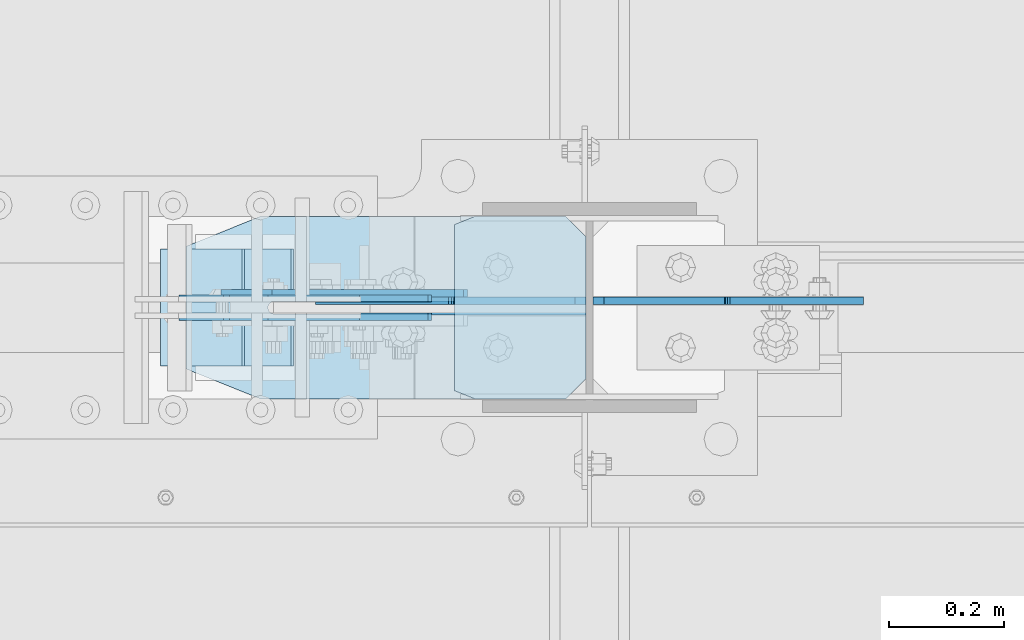
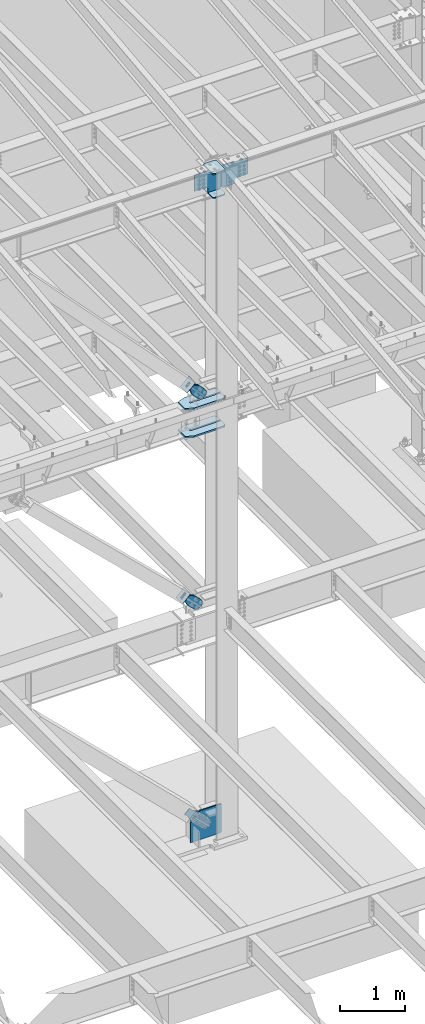
# One storey, part 1041 of 1179: 14 plates, 8 elements without a shape of their own.
"""IFC2X3 building model written with IfcOpenShell, lengths in millimetres."""

from ifc_helpers import new_model, si_unit, frame, origin_with_axes, place, context, subcontext, project, spatial, faceted_brep, material, type_object, element, aggregate, save


model = new_model("IFC2X3")

# Units and contexts
model_context = context("Model", 3, precision=1e-05, world=origin_with_axes())
body_context = subcontext(model_context, "Body", "Model", "MODEL_VIEW")
ifc_project = project(units=[si_unit("LENGTHUNIT", "METRE", prefix="MILLI"), si_unit("AREAUNIT", "SQUARE_METRE"), si_unit("VOLUMEUNIT", "CUBIC_METRE"), si_unit("MASSUNIT", "GRAM", prefix="KILO"), si_unit("TIMEUNIT", "SECOND"), si_unit("PLANEANGLEUNIT", "RADIAN"), si_unit("SOLIDANGLEUNIT", "STERADIAN"), si_unit("THERMODYNAMICTEMPERATUREUNIT", "DEGREE_CELSIUS"), si_unit("LUMINOUSINTENSITYUNIT", "LUMEN")], contexts=[model_context])

# Site, building, storey
site_placement = place(None, origin_with_axes())
site = spatial("IfcSite", under=ifc_project, at=site_placement, CompositionType="ELEMENT")
building_placement = place(site_placement, origin_with_axes())
building = spatial("IfcBuilding", under=site, at=building_placement, Name="Undefined", CompositionType="ELEMENT")
storey_placement = place(building_placement, origin_with_axes())
storey = spatial("IfcBuildingStorey", under=building, at=storey_placement, Name="Undefined", CompositionType="ELEMENT", Elevation=0.0)

# Assembly, plate
assembly_1_placement = place(storey_placement, origin_with_axes())
assembly_1 = element("IfcElementAssembly", 1, at=assembly_1_placement, inside=storey, AssemblyPlace="NOTDEFINED", PredefinedType="RIGID_FRAME")
ifc_material_1 = material(Name="STEEL/A36")
plate_type_1 = type_object("IfcPlateType", PredefinedType="NOTDEFINED")
plate_1_placement = place(assembly_1_placement, frame((15900.0877558765, 27066.875, 8392.98769805822), z_axis=(-0.724386095169384, 0.0, -0.689394506161205), x_axis=(0.689394506161205, 0.0, -0.724386095169384)))
plate_1 = element("IfcPlate", 2, at=plate_1_placement, type_object=plate_type_1, material=ifc_material_1, context=body_context, shape_type="Brep", body=[
    faceted_brep([(0.0, -6.34999999999854, 0.0), (-8.18545231595635e-11, -6.34999999999854, 91.5986124346418), (-8.18545231595635e-11, 6.34999999999854, 91.5986124346418), (0.0, 6.34999999999854, 0.0), (82.5500000001266, -6.34999999999854, 91.5986124347546), (82.5500000001266, 6.34999999999854, 91.5986124347546), (184.150000000493, -6.34999999999854, 136.286806217293), (184.150000000493, 6.34999999999854, 136.286806217293), (329.234985848627, -6.34999999999854, 136.286806217511), (329.234985848627, 6.34999999999854, 136.286806217511), (363.86305410257, -6.34999999999854, 129.398855183379), (363.86305410257, 6.34999999999854, 129.398855183379), (393.219312869078, -6.34999999999854, 109.783630186394), (393.219312869078, 6.34999999999854, 109.783630186394), (412.8345378661, -6.34999999999854, 80.4273714198789), (412.8345378661, 6.34999999999854, 80.4273714198789), (419.72248890029, -6.34999999999854, 45.7993092699908), (419.72248890029, 6.34999999999854, 45.7993092699908), (412.834537866132, -6.34999999999854, 11.171241015978), (412.834537866132, 6.34999999999854, 11.171241015978), (393.219312869132, -6.34999999999854, -18.1850177505985), (393.219312869132, 6.34999999999854, -18.1850177505985), (363.863054102636, -6.34999999999854, -37.8002427476786), (363.863054102636, 6.34999999999854, -37.8002427476786), (329.234988900062, -6.34999999999854, -44.6881937819198), (329.234988900062, 6.34999999999854, -44.6881937819198), (184.150000000598, -6.34999999999854, -44.6881937821345), (184.150000000598, 6.34999999999854, -44.6881937821345), (82.550000000203, -6.34999999999854, 1.2732925824821e-10), (82.550000000203, 6.34999999999854, 1.2732925824821e-10)], [[[0, 1, 2, 3]], [[1, 4, 5, 2]], [[4, 6, 7, 5]], [[6, 8, 9, 7]], [[8, 10, 11, 9]], [[10, 12, 13, 11]], [[12, 14, 15, 13]], [[14, 16, 17, 15]], [[16, 18, 19, 17]], [[18, 20, 21, 19]], [[20, 22, 23, 21]], [[22, 24, 25, 23]], [[24, 26, 27, 25]], [[26, 28, 29, 27]], [[28, 0, 3, 29]], [[5, 7, 9, 11, 13, 15, 17, 19, 21, 23, 25, 27, 29, 3, 2]], [[28, 26, 24, 22, 20, 18, 16, 14, 12, 10, 8, 6, 4, 1, 0]]]),
])
aggregate(assembly_1, [plate_1])

assembly_2_placement = place(storey_placement, origin_with_axes())
assembly_2 = element("IfcElementAssembly", 3, at=assembly_2_placement, inside=storey, AssemblyPlace="NOTDEFINED", PredefinedType="RIGID_FRAME")
plate_2_placement = place(assembly_2_placement, frame((15900.0877558765, 27035.125, 8392.98769805822), z_axis=(-0.724386095169384, 0.0, -0.689394506161205), x_axis=(0.689394506161205, 0.0, -0.724386095169384)))
plate_2 = element("IfcPlate", 4, at=plate_2_placement, type_object=plate_type_1, material=ifc_material_1, context=body_context, shape_type="Brep", body=[
    faceted_brep([(0.0, -6.34999999999854, 0.0), (-8.18545231595635e-11, -6.34999999999854, 91.5986124346418), (-8.18545231595635e-11, 6.34999999999854, 91.5986124346418), (0.0, 6.34999999999854, 0.0), (82.5500000001266, -6.34999999999854, 91.5986124347546), (82.5500000001266, 6.34999999999854, 91.5986124347546), (184.150000000493, -6.34999999999854, 136.286806217293), (184.150000000493, 6.34999999999854, 136.286806217293), (329.234985848627, -6.34999999999854, 136.286806217511), (329.234985848627, 6.34999999999854, 136.286806217511), (363.86305410257, -6.34999999999854, 129.398855183379), (363.86305410257, 6.34999999999854, 129.398855183379), (393.219312869078, -6.34999999999854, 109.783630186394), (393.219312869078, 6.34999999999854, 109.783630186394), (412.8345378661, -6.34999999999854, 80.4273714198789), (412.8345378661, 6.34999999999854, 80.4273714198789), (419.72248890029, -6.34999999999854, 45.7993092699908), (419.72248890029, 6.34999999999854, 45.7993092699908), (412.834537866132, -6.34999999999854, 11.171241015978), (412.834537866132, 6.34999999999854, 11.171241015978), (393.219312869132, -6.34999999999854, -18.1850177505985), (393.219312869132, 6.34999999999854, -18.1850177505985), (363.863054102636, -6.34999999999854, -37.8002427476786), (363.863054102636, 6.34999999999854, -37.8002427476786), (329.234988900062, -6.34999999999854, -44.6881937819198), (329.234988900062, 6.34999999999854, -44.6881937819198), (184.150000000598, -6.34999999999854, -44.6881937821345), (184.150000000598, 6.34999999999854, -44.6881937821345), (82.550000000203, -6.34999999999854, 1.2732925824821e-10), (82.550000000203, 6.34999999999854, 1.2732925824821e-10)], [[[0, 1, 2, 3]], [[1, 4, 5, 2]], [[4, 6, 7, 5]], [[6, 8, 9, 7]], [[8, 10, 11, 9]], [[10, 12, 13, 11]], [[12, 14, 15, 13]], [[14, 16, 17, 15]], [[16, 18, 19, 17]], [[18, 20, 21, 19]], [[20, 22, 23, 21]], [[22, 24, 25, 23]], [[24, 26, 27, 25]], [[26, 28, 29, 27]], [[28, 0, 3, 29]], [[5, 7, 9, 11, 13, 15, 17, 19, 21, 23, 25, 27, 29, 3, 2]], [[28, 26, 24, 22, 20, 18, 16, 14, 12, 10, 8, 6, 4, 1, 0]]]),
])
aggregate(assembly_2, [plate_2])

assembly_3_placement = place(storey_placement, origin_with_axes())
assembly_3 = element("IfcElementAssembly", 5, at=assembly_3_placement, inside=storey, Name="Plate", AssemblyPlace="NOTDEFINED", PredefinedType="RIGID_FRAME")
plate_type_2 = type_object("IfcPlateType", PredefinedType="NOTDEFINED")
plate_3_placement = place(assembly_3_placement, frame((15795.5025755752, 27152.6, 8289.07150028966), z_axis=(0.724386095169386, 0.0, 0.689394506161204), x_axis=(0.0, -1.0, 0.0)))
plate_3 = element("IfcPlate", 6, at=plate_3_placement, type_object=plate_type_2, material=ifc_material_1, Name="Plate", context=body_context, shape_type="Brep", body=[
    faceted_brep([(0.0, -3.17500000000109, 0.0), (0.0, -3.17500000000291, 203.200000000368), (0.0, 3.17499999998836, 203.200000000361), (0.0, 3.17500000000109, 7.27595761418343e-12), (203.199999999997, -3.17500000000291, 203.200000000368), (203.199999999997, 3.17499999998836, 203.200000000361), (203.199999999997, -3.17499999999927, 3.63797880709171e-12), (203.199999999997, 3.17499999999382, -3.63797880709171e-12)], [[[0, 1, 2, 3]], [[1, 4, 5, 2]], [[4, 6, 7, 5]], [[6, 0, 3, 7]], [[5, 7, 3, 2]], [[6, 4, 1, 0]]]),
])
aggregate(assembly_3, [plate_3])

assembly_4_placement = place(storey_placement, origin_with_axes())
assembly_4 = element("IfcElementAssembly", 7, at=assembly_4_placement, inside=storey, Name="Plate", AssemblyPlace="NOTDEFINED", PredefinedType="RIGID_FRAME")
plate_4_placement = place(assembly_4_placement, frame((15716.0049864099, 27152.6, 4367.90725387556), z_axis=(0.694497308871752, 0.0, 0.719495300867138), x_axis=(0.0, -1.0, 0.0)))
plate_4 = element("IfcPlate", 8, at=plate_4_placement, type_object=plate_type_2, material=ifc_material_1, Name="Plate", context=body_context, shape_type="Brep", body=[
    faceted_brep([(0.0, -3.17500000000109, 0.0), (0.0, -3.17500000000291, 203.200000000368), (0.0, 3.17499999998836, 203.200000000361), (0.0, 3.17500000000109, 7.27595761418343e-12), (203.199999999997, -3.17500000000291, 203.200000000368), (203.199999999997, 3.17499999998836, 203.200000000361), (203.199999999997, -3.17499999999927, 3.63797880709171e-12), (203.199999999997, 3.17499999999382, -3.63797880709171e-12)], [[[0, 1, 2, 3]], [[1, 4, 5, 2]], [[4, 6, 7, 5]], [[6, 0, 3, 7]], [[5, 7, 3, 2]], [[6, 4, 1, 0]]]),
])
aggregate(assembly_4, [plate_4])

# Assembly, plates
assembly_5_placement = place(storey_placement, origin_with_axes())
assembly_5 = element("IfcElementAssembly", 9, at=assembly_5_placement, inside=storey, Name="COLUMN", AssemblyPlace="NOTDEFINED", PredefinedType="RIGID_FRAME")
ifc_material_2 = material(Name="STEEL/A572-GR.50")
plate_type_3 = type_object("IfcPlateType", PredefinedType="NOTDEFINED")
plate_5_placement = place(assembly_5_placement, frame((16224.25, 27209.75, 11813.7781250357), z_axis=(0.0, -1.0, 0.0), x_axis=(1.0, 0.0, 0.0)))
plate_5 = element("IfcPlate", 10, at=plate_5_placement, type_object=plate_type_3, material=ifc_material_2, Name="PLATE", context=body_context, shape_type="Brep", body=[
    faceted_brep([(36.5125000000007, -11.1124999999993, 317.5), (36.5125000000007, 11.1124999999993, 317.5), (0.0, 11.1124999999993, 302.895), (0.0, -11.1124999999993, 302.895), (36.5125000000007, -11.1124999999993, 0.0), (0.0, -11.1124999999993, 14.6049999999996), (0.0, 11.1124999999993, 14.6049999999996), (36.5125000000007, 11.1124999999993, 0.0), (193.675000762942, 11.1124999999993, 0.0), (193.675000762942, -11.1124999999993, 0.0), (228.600000000002, -11.1124999999993, 34.9249992370605), (228.600000000002, 11.1124999999993, 34.9249992370605), (228.600000000002, -11.1124999999993, 282.575000762939), (228.600000000002, 11.1124999999993, 282.575000762939), (193.675000762942, -11.1124999999993, 317.5), (193.675000762942, 11.1124999999993, 317.5)], [[[0, 1, 2, 3]], [[4, 5, 6, 7]], [[8, 9, 4, 7]], [[10, 9, 8, 11]], [[12, 10, 11, 13]], [[14, 12, 13, 15]], [[9, 10, 12, 14, 0, 3, 5, 4]], [[3, 2, 6, 5]], [[2, 1, 15, 13, 11, 8, 7, 6]], [[14, 15, 1, 0]]]),
])
plate_6_placement = place(assembly_5_placement, frame((16224.25, 27209.75, 12258.2781250357), z_axis=(0.0, -1.0, 0.0), x_axis=(1.0, 0.0, 0.0)))
plate_6 = element("IfcPlate", 11, at=plate_6_placement, type_object=plate_type_3, material=ifc_material_2, Name="PLATE", context=body_context, shape_type="Brep", body=[
    faceted_brep([(36.5125000000007, -11.1124999999993, 317.5), (36.5125000000007, 11.1124999999993, 317.5), (0.0, 11.1124999999993, 302.895), (0.0, -11.1124999999993, 302.895), (36.5125000000007, -11.1124999999993, 0.0), (0.0, -11.1124999999993, 14.6049999999996), (0.0, 11.1124999999993, 14.6049999999996), (36.5125000000007, 11.1124999999993, 0.0), (193.675000762942, 11.1124999999993, 0.0), (193.675000762942, -11.1124999999993, 0.0), (228.600000000002, -11.1124999999993, 34.9249992370605), (228.600000000002, 11.1124999999993, 34.9249992370605), (228.600000000002, -11.1124999999993, 282.575000762939), (228.600000000002, 11.1124999999993, 282.575000762939), (193.675000762942, -11.1124999999993, 317.5), (193.675000762942, 11.1124999999993, 317.5)], [[[0, 1, 2, 3]], [[4, 5, 6, 7]], [[8, 9, 4, 7]], [[10, 9, 8, 11]], [[12, 10, 11, 13]], [[14, 12, 13, 15]], [[9, 10, 12, 14, 0, 3, 5, 4]], [[3, 2, 6, 5]], [[2, 1, 15, 13, 11, 8, 7, 6]], [[14, 15, 1, 0]]]),
])
plate_type_4 = type_object("IfcPlateType", PredefinedType="NOTDEFINED")
plate_7_placement = place(assembly_5_placement, frame((16465.5499973619, 27062.9062499701, 11843.9406250357), z_axis=(0.707106781186573, 0.0, 0.707106781186522), x_axis=(0.707106781186522, 0.0, -0.707106781186573)))
plate_7 = element("IfcPlate", 12, at=plate_7_placement, type_object=plate_type_4, material=ifc_material_2, Name="PLATE", context=body_context, shape_type="Brep", body=[
    faceted_brep([(0.0, -6.34999999999854, 0.0), (-271.652749686205, -6.35000000000036, 271.652745638487), (-271.652749686205, 6.35000000000036, 271.652745638487), (0.0, 6.34999999999854, 0.0), (-271.652749686187, -6.35000000000036, 298.59351380097), (-271.652749686187, 6.35000000000036, 298.59351380097), (-123.478521665553, -6.34999999999854, 446.767742022512), (-123.478521665553, 6.34999999999854, 446.767742022512), (-118.32830100301, -6.34999999999854, 443.326474595233), (-118.32830100301, 6.34999999999854, 443.326474595233), (-112.253201514221, -6.34999999999854, 442.118062173842), (-112.253201514221, 6.34999999999854, 442.118062173842), (-106.178102025433, -6.34999999999854, 443.326474595215), (-106.178102025433, 6.34999999999854, 443.326474595215), (-101.027881362903, -6.34999999999854, 446.767742022486), (-101.027881362903, 6.34999999999854, 446.767742022486), (58.3716647852852, -6.34999999999854, 606.167288170658), (58.3716647852852, 6.34999999999854, 606.167288170658), (273.897811691008, -6.34999999999854, 390.641141264914), (273.897811691008, 6.34999999999854, 390.641141264914), (121.233457363867, -6.34999999999854, 237.976786937787), (121.233457363867, 6.34999999999854, 237.976786937787), (115.727429562927, -6.34999999999854, 229.736434001497), (115.727429562927, 6.34999999999854, 229.736434001497), (113.793969717764, -6.34999999999854, 220.016274965419), (113.793969717764, 6.34999999999854, 220.016274965419), (115.727429562949, -6.34999999999854, 210.296115929337), (115.727429562949, 6.34999999999854, 210.296115929337), (121.233457363913, -6.34999999999854, 202.05576299303), (121.233457363913, 6.34999999999854, 202.05576299303), (175.114994360907, -6.34999999999854, 148.174225997692), (175.114994360907, 6.34999999999854, 148.174225997692), (26.9407683631471, -6.34999999999854, -6.91215973347425e-11), (26.9407683631471, 6.34999999999854, -6.91215973347425e-11)], [[[0, 1, 2, 3]], [[1, 4, 5, 2]], [[4, 6, 7, 5]], [[6, 8, 9, 7]], [[8, 10, 11, 9]], [[10, 12, 13, 11]], [[12, 14, 15, 13]], [[14, 16, 17, 15]], [[16, 18, 19, 17]], [[18, 20, 21, 19]], [[20, 22, 23, 21]], [[22, 24, 25, 23]], [[24, 26, 27, 25]], [[26, 28, 29, 27]], [[28, 30, 31, 29]], [[30, 32, 33, 31]], [[32, 0, 3, 33]], [[5, 7, 9, 11, 13, 15, 17, 19, 21, 23, 25, 27, 29, 31, 33, 3, 2]], [[32, 30, 28, 26, 24, 22, 20, 18, 16, 14, 12, 10, 8, 6, 4, 1, 0]]]),
])
plate_8_placement = place(assembly_5_placement, frame((16452.85, 27062.9062499701, 11843.9406250357), z_axis=(-0.707106781186532, 0.0, 0.707106781186563), x_axis=(-0.707106781186564, 0.0, -0.707106781186531)))
plate_8 = element("IfcPlate", 13, at=plate_8_placement, type_object=plate_type_4, material=ifc_material_2, Name="PLATE", context=body_context, shape_type="Brep", body=[
    faceted_brep([(0.0, -6.34999999999854, 0.0), (-271.652749686205, -6.35000000000036, 271.652745638487), (-271.652749686205, 6.35000000000036, 271.652745638487), (0.0, 6.34999999999854, 0.0), (-271.652749686187, -6.35000000000036, 298.59351380097), (-271.652749686187, 6.35000000000036, 298.59351380097), (-123.478521665553, -6.34999999999854, 446.767742022512), (-123.478521665553, 6.34999999999854, 446.767742022512), (-118.32830100301, -6.34999999999854, 443.326474595233), (-118.32830100301, 6.34999999999854, 443.326474595233), (-112.253201514221, -6.34999999999854, 442.118062173842), (-112.253201514221, 6.34999999999854, 442.118062173842), (-106.178102025433, -6.34999999999854, 443.326474595215), (-106.178102025433, 6.34999999999854, 443.326474595215), (-101.027881362903, -6.34999999999854, 446.767742022486), (-101.027881362903, 6.34999999999854, 446.767742022486), (58.3716647852852, -6.34999999999854, 606.167288170658), (58.3716647852852, 6.34999999999854, 606.167288170658), (273.897811691008, -6.34999999999854, 390.641141264914), (273.897811691008, 6.34999999999854, 390.641141264914), (121.233457363867, -6.34999999999854, 237.976786937787), (121.233457363867, 6.34999999999854, 237.976786937787), (115.727429562927, -6.34999999999854, 229.736434001497), (115.727429562927, 6.34999999999854, 229.736434001497), (113.793969717764, -6.34999999999854, 220.016274965419), (113.793969717764, 6.34999999999854, 220.016274965419), (115.727429562949, -6.34999999999854, 210.296115929337), (115.727429562949, 6.34999999999854, 210.296115929337), (121.233457363913, -6.34999999999854, 202.05576299303), (121.233457363913, 6.34999999999854, 202.05576299303), (175.114994360907, -6.34999999999854, 148.174225997692), (175.114994360907, 6.34999999999854, 148.174225997692), (26.9407683631471, -6.34999999999854, -6.91215973347425e-11), (26.9407683631471, 6.34999999999854, -6.91215973347425e-11)], [[[0, 1, 2, 3]], [[1, 4, 5, 2]], [[4, 6, 7, 5]], [[6, 8, 9, 7]], [[8, 10, 11, 9]], [[10, 12, 13, 11]], [[12, 14, 15, 13]], [[14, 16, 17, 15]], [[16, 18, 19, 17]], [[18, 20, 21, 19]], [[20, 22, 23, 21]], [[22, 24, 25, 23]], [[24, 26, 27, 25]], [[26, 28, 29, 27]], [[28, 30, 31, 29]], [[30, 32, 33, 31]], [[32, 0, 3, 33]], [[5, 7, 9, 11, 13, 15, 17, 19, 21, 23, 25, 27, 29, 31, 33, 3, 2]], [[32, 30, 28, 26, 24, 22, 20, 18, 16, 14, 12, 10, 8, 6, 4, 1, 0]]]),
])
plate_type_5 = type_object("IfcPlateType", PredefinedType="NOTDEFINED")
plate_9_placement = place(assembly_5_placement, frame((15757.5160799849, 27209.75, 7478.7125), z_axis=(1.0, 0.0, 0.0), x_axis=(0.0, -1.0, 0.0)))
plate_9 = element("IfcPlate", 14, at=plate_9_placement, type_object=plate_type_5, material=ifc_material_2, Name="PLATE", context=body_context, shape_type="Brep", body=[
    faceted_brep([(147.637499999997, -14.2875000000004, 695.33391818764), (147.637499999997, -14.2875000000004, 153.987500190735), (147.637499999997, 14.2875000000004, 153.987500190735), (147.637499999997, 14.2875000000004, 695.33391818764), (148.483388709483, -14.2875000000004, 149.734930475586), (148.483388709483, 14.2875000000004, 149.734930475586), (150.892275949926, -14.2875000000004, 146.12977594993), (150.892275949926, 14.2875000000004, 146.12977594993), (154.497430475585, -14.2875000000004, 143.720888709488), (154.497430475585, 14.2875000000004, 143.720888709488), (158.750000190732, -14.2875000000004, 142.875), (158.750000190732, 14.2875000000004, 142.875), (163.002569524415, -14.2875000000004, 143.720888709488), (163.002569524415, 14.2875000000004, 143.720888709488), (166.607724050074, -14.2875000000004, 146.12977594993), (166.607724050074, 14.2875000000004, 146.12977594993), (169.016611290517, -14.2875000000004, 149.734930475586), (169.016611290517, 14.2875000000004, 149.734930475586), (169.862500000003, -14.2875000000004, 153.987500190735), (169.862500000003, 14.2875000000004, 153.987500190735), (169.862500000003, -14.2875000000004, 695.333920014917), (169.862500000003, 14.2875000000004, 695.333920014917), (0.0, -14.2875000000004, 660.408918950579), (34.9249992370605, -14.2875000000004, 695.33391818764), (34.9249992370605, 14.2875000000004, 695.33391818764), (0.0, 14.2875000000004, 660.408918950579), (0.0, -14.2875000000004, 130.175003051758), (0.0, 14.2875000000004, 130.175003051758), (52.3875007629395, -14.2875000000004, 0.0), (52.3875007629395, 14.2875000000004, 0.0), (265.112499237061, -14.2875000000004, 0.0), (265.112499237061, 14.2875000000004, 0.0), (317.5, -14.2875000000004, 130.175003051758), (317.5, 14.2875000000004, 130.175003051758), (317.5, -14.2875000000004, 660.408918950579), (317.5, 14.2875000000004, 660.408918950579), (282.575000762939, -14.2875000000004, 695.33391818764), (282.575000762939, 14.2875000000004, 695.33391818764)], [[[0, 1, 2, 3]], [[4, 5, 2, 1]], [[6, 7, 5, 4]], [[8, 9, 7, 6]], [[10, 11, 9, 8]], [[12, 13, 11, 10]], [[14, 15, 13, 12]], [[16, 17, 15, 14]], [[18, 19, 17, 16]], [[20, 21, 19, 18]], [[22, 23, 24, 25]], [[26, 22, 25, 27]], [[28, 26, 27, 29]], [[30, 28, 29, 31]], [[32, 30, 31, 33]], [[34, 32, 33, 35]], [[36, 34, 35, 37]], [[16, 14, 12, 10, 8, 6, 4, 1, 0, 23, 22, 26, 28, 30, 32, 34, 36, 20, 18]], [[24, 23, 0, 3]], [[37, 35, 33, 31, 29, 27, 25, 24, 3, 2, 5, 7, 9, 11, 13, 15, 17, 19, 21]], [[36, 37, 21, 20]]]),
])
plate_10_placement = place(assembly_5_placement, frame((15757.5160799849, 27209.75, 7999.4125), z_axis=(1.0, 0.0, 0.0), x_axis=(0.0, -1.0, 0.0)))
plate_10 = element("IfcPlate", 15, at=plate_10_placement, type_object=plate_type_5, material=ifc_material_2, Name="PLATE", context=body_context, shape_type="Brep", body=[
    faceted_brep([(147.637499999997, -14.2875000000004, 695.33391818764), (147.637499999997, -14.2875000000004, 153.987500190735), (147.637499999997, 14.2875000000004, 153.987500190735), (147.637499999997, 14.2875000000004, 695.33391818764), (148.483388709483, -14.2875000000004, 149.734930475586), (148.483388709483, 14.2875000000004, 149.734930475586), (150.892275949926, -14.2875000000004, 146.12977594993), (150.892275949926, 14.2875000000004, 146.12977594993), (154.497430475585, -14.2875000000004, 143.720888709488), (154.497430475585, 14.2875000000004, 143.720888709488), (158.750000190732, -14.2875000000004, 142.875), (158.750000190732, 14.2875000000004, 142.875), (163.002569524415, -14.2875000000004, 143.720888709488), (163.002569524415, 14.2875000000004, 143.720888709488), (166.607724050074, -14.2875000000004, 146.12977594993), (166.607724050074, 14.2875000000004, 146.12977594993), (169.016611290517, -14.2875000000004, 149.734930475586), (169.016611290517, 14.2875000000004, 149.734930475586), (169.862500000003, -14.2875000000004, 153.987500190735), (169.862500000003, 14.2875000000004, 153.987500190735), (169.862500000003, -14.2875000000004, 695.333920014917), (169.862500000003, 14.2875000000004, 695.333920014917), (0.0, -14.2875000000004, 660.408918950579), (34.9249992370605, -14.2875000000004, 695.33391818764), (34.9249992370605, 14.2875000000004, 695.33391818764), (0.0, 14.2875000000004, 660.408918950579), (0.0, -14.2875000000004, 130.175003051758), (0.0, 14.2875000000004, 130.175003051758), (52.3875007629395, -14.2875000000004, 0.0), (52.3875007629395, 14.2875000000004, 0.0), (265.112499237061, -14.2875000000004, 0.0), (265.112499237061, 14.2875000000004, 0.0), (317.5, -14.2875000000004, 130.175003051758), (317.5, 14.2875000000004, 130.175003051758), (317.5, -14.2875000000004, 660.408918950579), (317.5, 14.2875000000004, 660.408918950579), (282.575000762939, -14.2875000000004, 695.33391818764), (282.575000762939, 14.2875000000004, 695.33391818764)], [[[0, 1, 2, 3]], [[4, 5, 2, 1]], [[6, 7, 5, 4]], [[8, 9, 7, 6]], [[10, 11, 9, 8]], [[12, 13, 11, 10]], [[14, 15, 13, 12]], [[16, 17, 15, 14]], [[18, 19, 17, 16]], [[20, 21, 19, 18]], [[22, 23, 24, 25]], [[26, 22, 25, 27]], [[28, 26, 27, 29]], [[30, 28, 29, 31]], [[32, 30, 31, 33]], [[34, 32, 33, 35]], [[36, 34, 35, 37]], [[16, 14, 12, 10, 8, 6, 4, 1, 0, 23, 22, 26, 28, 30, 32, 34, 36, 20, 18]], [[24, 23, 0, 3]], [[37, 35, 33, 31, 29, 27, 25, 24, 3, 2, 5, 7, 9, 11, 13, 15, 17, 19, 21]], [[36, 37, 21, 20]]]),
])

# Assembly, plate
assembly_6_placement = place(storey_placement, origin_with_axes())
assembly_6 = element("IfcElementAssembly", 16, at=assembly_6_placement, inside=storey, AssemblyPlace="NOTDEFINED", PredefinedType="RIGID_FRAME")
plate_type_6 = type_object("IfcPlateType", PredefinedType="NOTDEFINED")
plate_11_placement = place(assembly_6_placement, frame((15823.237581679, 27066.875, 4483.5712706716), z_axis=(-0.694497308871754, 0.0, -0.719495300867137), x_axis=(0.719495300867137, 0.0, -0.694497308871754)))
plate_11 = element("IfcPlate", 17, at=plate_11_placement, type_object=plate_type_6, material=ifc_material_1, context=body_context, shape_type="Brep", body=[
    faceted_brep([(0.0, -6.34999999999854, 0.0), (-4.35647962149233e-10, -6.34999999999854, 112.184930806416), (-4.35647962149233e-10, 6.34999999999854, 112.184930806416), (0.0, 6.34999999999854, 0.0), (82.5499999996491, -6.34999999999854, 112.184930806461), (82.5499999996491, 6.34999999999854, 112.184930806461), (184.149999999618, -6.34999999999854, 149.75496540347), (184.149999999618, 6.34999999999854, 149.75496540347), (327.919242323534, -6.34999999999854, 149.754965403559), (327.919242323534, 6.34999999999854, 149.754965403559), (363.762328723451, -6.34999999999854, 142.625332233587), (363.762328723451, 6.34999999999854, 142.625332233587), (394.148630137406, -6.34999999999854, 122.321854743475), (394.148630137406, 6.34999999999854, 122.321854743475), (414.452107627645, -6.34999999999854, 91.9355533295929), (414.452107627645, 6.34999999999854, 91.9355533295929), (421.581740797776, -6.34999999999854, 56.0924638777396), (421.581740797776, 6.34999999999854, 56.0924638777396), (414.452107627878, -6.34999999999854, 20.2493774776722), (414.452107627878, 6.34999999999854, 20.2493774776722), (394.14863013775, -6.34999999999854, -10.1369239363994), (394.14863013775, 6.34999999999854, -10.1369239363994), (363.762328723789, -6.34999999999854, -30.4404014266784), (363.762328723789, 6.34999999999854, -30.4404014266784), (327.919240798041, -6.34999999999854, -37.570034596738), (327.919240798041, 6.34999999999854, -37.570034596738), (184.150000000338, -6.34999999999854, -37.5700345968289), (184.150000000338, 6.34999999999854, -37.5700345968289), (82.550000000203, -6.34999999999854, 1.2732925824821e-10), (82.550000000203, 6.34999999999854, 1.2732925824821e-10)], [[[0, 1, 2, 3]], [[1, 4, 5, 2]], [[4, 6, 7, 5]], [[6, 8, 9, 7]], [[8, 10, 11, 9]], [[10, 12, 13, 11]], [[12, 14, 15, 13]], [[14, 16, 17, 15]], [[16, 18, 19, 17]], [[18, 20, 21, 19]], [[20, 22, 23, 21]], [[22, 24, 25, 23]], [[24, 26, 27, 25]], [[26, 28, 29, 27]], [[28, 0, 3, 29]], [[5, 7, 9, 11, 13, 15, 17, 19, 21, 23, 25, 27, 29, 3, 2]], [[28, 26, 24, 22, 20, 18, 16, 14, 12, 10, 8, 6, 4, 1, 0]]]),
])
aggregate(assembly_6, [plate_11])

assembly_7_placement = place(storey_placement, origin_with_axes())
assembly_7 = element("IfcElementAssembly", 18, at=assembly_7_placement, inside=storey, AssemblyPlace="NOTDEFINED", PredefinedType="RIGID_FRAME")
plate_12_placement = place(assembly_7_placement, frame((15823.237581679, 27035.125, 4483.5712706716), z_axis=(-0.694497308871754, 0.0, -0.719495300867137), x_axis=(0.719495300867137, 0.0, -0.694497308871754)))
plate_12 = element("IfcPlate", 19, at=plate_12_placement, type_object=plate_type_6, material=ifc_material_1, context=body_context, shape_type="Brep", body=[
    faceted_brep([(0.0, -6.34999999999854, 0.0), (-4.35647962149233e-10, -6.34999999999854, 112.184930806416), (-4.35647962149233e-10, 6.34999999999854, 112.184930806416), (0.0, 6.34999999999854, 0.0), (82.5499999996491, -6.34999999999854, 112.184930806461), (82.5499999996491, 6.34999999999854, 112.184930806461), (184.149999999618, -6.34999999999854, 149.75496540347), (184.149999999618, 6.34999999999854, 149.75496540347), (327.919242323534, -6.34999999999854, 149.754965403559), (327.919242323534, 6.34999999999854, 149.754965403559), (363.762328723451, -6.34999999999854, 142.625332233587), (363.762328723451, 6.34999999999854, 142.625332233587), (394.148630137406, -6.34999999999854, 122.321854743475), (394.148630137406, 6.34999999999854, 122.321854743475), (414.452107627645, -6.34999999999854, 91.9355533295929), (414.452107627645, 6.34999999999854, 91.9355533295929), (421.581740797776, -6.34999999999854, 56.0924638777396), (421.581740797776, 6.34999999999854, 56.0924638777396), (414.452107627878, -6.34999999999854, 20.2493774776722), (414.452107627878, 6.34999999999854, 20.2493774776722), (394.14863013775, -6.34999999999854, -10.1369239363994), (394.14863013775, 6.34999999999854, -10.1369239363994), (363.762328723789, -6.34999999999854, -30.4404014266784), (363.762328723789, 6.34999999999854, -30.4404014266784), (327.919240798041, -6.34999999999854, -37.570034596738), (327.919240798041, 6.34999999999854, -37.570034596738), (184.150000000338, -6.34999999999854, -37.5700345968289), (184.150000000338, 6.34999999999854, -37.5700345968289), (82.550000000203, -6.34999999999854, 1.2732925824821e-10), (82.550000000203, 6.34999999999854, 1.2732925824821e-10)], [[[0, 1, 2, 3]], [[1, 4, 5, 2]], [[4, 6, 7, 5]], [[6, 8, 9, 7]], [[8, 10, 11, 9]], [[10, 12, 13, 11]], [[12, 14, 15, 13]], [[14, 16, 17, 15]], [[16, 18, 19, 17]], [[18, 20, 21, 19]], [[20, 22, 23, 21]], [[22, 24, 25, 23]], [[24, 26, 27, 25]], [[26, 28, 29, 27]], [[28, 0, 3, 29]], [[5, 7, 9, 11, 13, 15, 17, 19, 21, 23, 25, 27, 29, 3, 2]], [[28, 26, 24, 22, 20, 18, 16, 14, 12, 10, 8, 6, 4, 1, 0]]]),
])
aggregate(assembly_7, [plate_12])

assembly_8_placement = place(storey_placement, origin_with_axes())
assembly_8 = element("IfcElementAssembly", 20, at=assembly_8_placement, inside=storey, AssemblyPlace="NOTDEFINED", PredefinedType="RIGID_FRAME")
plate_type_7 = type_object("IfcPlateType", PredefinedType="NOTDEFINED")
plate_13_placement = place(assembly_8_placement, frame((15907.5429418252, 27073.225, 413.540432750507), z_axis=(-0.699860687134476, 0.0, -0.714279370137245), x_axis=(0.714279370137245, 0.0, -0.699860687134476)))
plate_13 = element("IfcPlate", 21, at=plate_13_placement, type_object=plate_type_7, material=ifc_material_1, context=body_context, shape_type="Brep", body=[
    faceted_brep([(0.0, -9.52499999999964, 0.0), (-5.72072167415172e-10, -9.52500000000146, 127.026455577978), (-5.72072167415172e-10, 9.52500000000146, 127.026455577978), (0.0, 9.52499999999964, 0.0), (82.5499999996218, -9.52500000000146, 127.02645557804), (82.5499999996218, 9.52500000000146, 127.02645557804), (184.149999999816, -9.52500000000146, 160.350727789162), (184.149999999816, 9.52500000000146, 160.350727789162), (402.829297671884, -9.52500000000146, 160.350727789319), (402.829297671884, 9.52500000000146, 160.350727789319), (439.887405137379, -9.52500000000146, 152.97941190279), (439.887405137379, 9.52500000000146, 152.97941190279), (471.303751673868, -9.52500000000146, 131.987680265722), (471.303751673868, 9.52500000000146, 131.987680265722), (492.295483311087, -9.52500000000146, 100.571333729322), (492.295483311087, 9.52500000000146, 100.571333729322), (499.666799197799, -9.52500000000146, 63.5132293155057), (499.666799197799, 9.52500000000146, 63.5132293155057), (492.295483311342, -9.52500000000146, 26.4551218498), (492.295483311342, 9.52500000000146, 26.4551218498), (471.303751674215, -9.52500000000146, -4.96122468687645), (471.303751674215, 9.52500000000146, -4.96122468687645), (439.887405137664, -9.52500000000146, -25.9529563241722), (439.887405137664, 9.52500000000146, -25.9529563241722), (402.829299197954, -9.52500000000146, -33.3242722108225), (402.829299197954, 9.52500000000146, -33.3242722108225), (184.150000000667, -9.52500000000146, -33.324272210979), (184.150000000667, 9.52500000000146, -33.324272210979), (82.5499999997119, -9.52500000000146, 1.81898940354586e-11), (82.5499999997119, 9.52500000000146, 1.81898940354586e-11)], [[[0, 1, 2, 3]], [[1, 4, 5, 2]], [[4, 6, 7, 5]], [[6, 8, 9, 7]], [[8, 10, 11, 9]], [[10, 12, 13, 11]], [[12, 14, 15, 13]], [[14, 16, 17, 15]], [[16, 18, 19, 17]], [[18, 20, 21, 19]], [[20, 22, 23, 21]], [[22, 24, 25, 23]], [[24, 26, 27, 25]], [[26, 28, 29, 27]], [[28, 0, 3, 29]], [[5, 7, 9, 11, 13, 15, 17, 19, 21, 23, 25, 27, 29, 3, 2]], [[28, 26, 24, 22, 20, 18, 16, 14, 12, 10, 8, 6, 4, 1, 0]]]),
])
aggregate(assembly_8, [plate_13])

# Plate
plate_type_8 = type_object("IfcPlateType", PredefinedType="NOTDEFINED")
plate_14_placement = place(assembly_5_placement, frame((16452.85, 27051.0, -215.9), z_axis=(0.0, 0.0, 1.0), x_axis=(-1.0, 0.0, 0.0)))
plate_14 = element("IfcPlate", 22, at=plate_14_placement, type_object=plate_type_8, material=ifc_material_2, Name="PLATE", context=body_context, shape_type="Brep", body=[
    faceted_brep([(0.0, -12.7000000000007, 19.0500000000029), (0.0, -12.7000000000007, 542.50662338178), (0.0, 12.7000000000007, 542.50662338178), (0.0, 12.7000000000007, 19.0500000000029), (372.673702658971, -12.7000000000007, 542.50662338178), (372.673702658971, 12.7000000000007, 542.50662338178), (543.772144146171, -12.7000000000007, 367.883174367477), (543.772144146171, 12.7000000000007, 367.883174367477), (543.772144146171, -12.7000000000007, 0.0), (543.772144146171, 12.7000000000007, 0.0), (19.0499992370605, -12.6999999999971, 0.0), (19.0499992370605, 12.6999999999971, 0.0)], [[[0, 1, 2, 3]], [[1, 4, 5, 2]], [[4, 6, 7, 5]], [[6, 8, 9, 7]], [[8, 10, 11, 9]], [[10, 0, 3, 11]], [[5, 7, 9, 11, 3, 2]], [[10, 8, 6, 4, 1, 0]]]),
])

aggregate(assembly_5, [plate_7, plate_5, plate_6, plate_8, plate_9, plate_10, plate_14])

save(model, "model.ifc")
